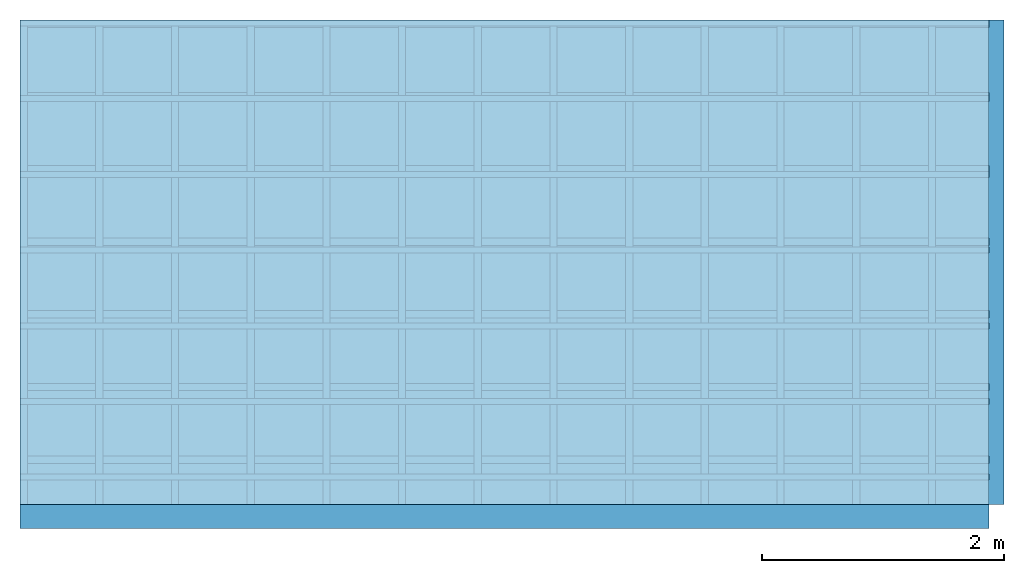
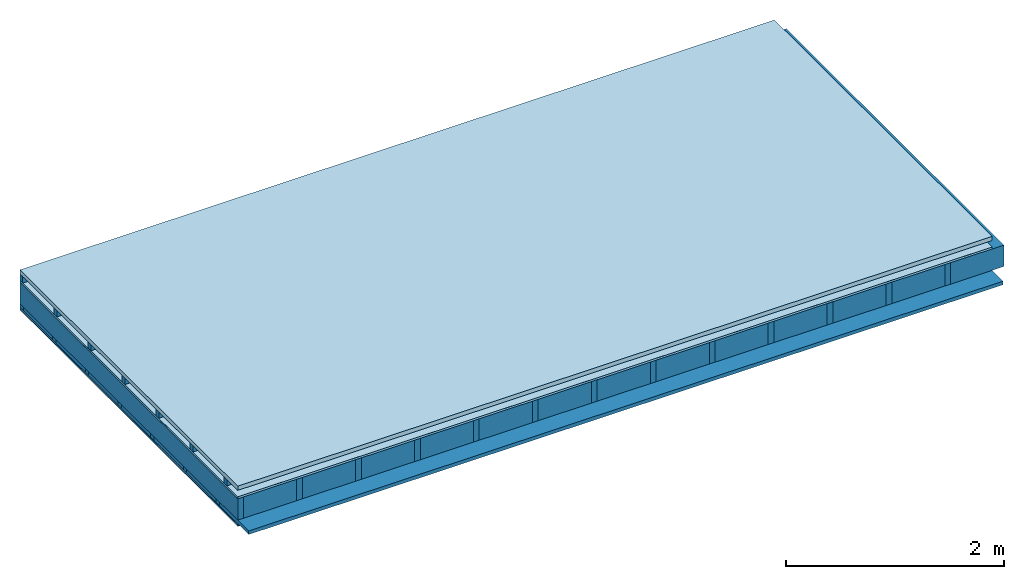
# One storey: 5 members, 5 plates, 1 element without a shape of its own.
"""IFC4 building model written with IfcOpenShell, lengths in metres."""

from ifc_helpers import new_model, si_unit, derived_unit, direction, frame, frame_2d, origin, origin_with_axes, place, context, project, spatial, rectangle, extrude, material, layer, layer_set, type_object, element, aggregate, save


model = new_model("IFC4")

# Units and contexts
plan_context = context("Plan", 3, precision=1e-05, world=origin(), true_north=direction((0.0, 1.0)))
model_context = context("Model", 3, precision=1e-05, world=origin(), true_north=direction((0.0, 1.0)))
ifc_project = project(units=[si_unit("LENGTHUNIT", "METRE"), derived_unit("SOUNDPRESSUREUNIT", [(si_unit("PRESSUREUNIT", "PASCAL", prefix="MICRO"), 0)]), si_unit("ENERGYUNIT", "JOULE", prefix="MEGA"), si_unit("MASSUNIT", "GRAM", prefix="KILO"), derived_unit("THERMALTRANSMITTANCEUNIT", [(si_unit("POWERUNIT", "WATT"), 1), (si_unit("AREAUNIT", "SQUARE_METRE"), -1), (si_unit("THERMODYNAMICTEMPERATUREUNIT", "KELVIN"), -1)]), derived_unit("AREADENSITYUNIT", [(si_unit("MASSUNIT", "GRAM", prefix="KILO"), 1), (si_unit("AREAUNIT", "SQUARE_METRE"), -1)]), derived_unit("USERDEFINED", [(si_unit("ENERGYUNIT", "JOULE", prefix="MEGA"), 1), (si_unit("AREAUNIT", "SQUARE_METRE"), -1)])], contexts=[plan_context, model_context])

# Site, building, storey
site = spatial("IfcSite", under=ifc_project)
building_placement = place(None, origin())
building = spatial("IfcBuilding", under=site, at=building_placement)
storey_placement = place(building_placement, origin())
storey = spatial("IfcBuildingStorey", under=building, at=storey_placement)

# Slab, members, plates
ifc_material_1 = material(Name="Roof tiles", Category="03.015")
ifc_layer_1 = layer(ifc_material_1, 0.047, Name="Roofing")
ifc_layer_2 = layer(None, 0.072, Name="Battens / profiles")
ifc_material_2 = material(Name="Roofing underlay", Category="09.008")
ifc_layer_3 = layer(ifc_material_2, 0.00018, Name="Under the roof")
ifc_material_3 = material(Category="10.009")
ifc_layer_4 = layer(ifc_material_3, 0.022, Name="Exterior insulation layer 1")
ifc_material_4 = material(Name="no composite action")
ifc_layer_5 = layer(ifc_material_4, 0.0, Name="Bond")
ifc_layer_6 = layer(None, 0.24, Name="Supporting structure")
ifc_material_5 = material(Name="of the art")
ifc_layer_7 = layer(ifc_material_5, 0.0, Name="Bond")
ifc_layer_8 = layer(None, 0.04, Name="Battens / profiles")
ifc_material_6 = material(Category="03.007")
ifc_layer_9 = layer(ifc_material_6, 0.015, Name="Covering below 1st layer")
ifc_layer_10 = layer(ifc_material_6, 0.015, Name="Covering below 2nd layer")
ifc_material_7 = material(Name="Glued joints")
ifc_layer_11 = layer(ifc_material_7, 0.0, Name="Surface below")
ifc_layer_set = layer_set([ifc_layer_1, ifc_layer_2, ifc_layer_3, ifc_layer_4, ifc_layer_5, ifc_layer_6, ifc_layer_7, ifc_layer_8, ifc_layer_9, ifc_layer_10, ifc_layer_11])
slab_type = type_object("IfcSlabType", Name="E0102", PredefinedType="NOTDEFINED", material=ifc_layer_set)
slab_placement = place(None, frame((0.0, 0.0, 0.0), z_axis=(0.0, 0.0, -1.0), x_axis=(1.0, 0.0, 0.0)))
slab = element("IfcSlab", 1, at=slab_placement, inside=storey, type_object=slab_type, material=ifc_layer_set, Name="Slab #1")
ifc_material_8 = material()
member_1_placement = place(slab_placement, origin())
member_1 = element("IfcMember", 2, at=member_1_placement, material=ifc_material_8, Name="Battens / profiles", context=plan_context, shape_type="SweptSolid", body=[
    extrude(rectangle(XDim=0.05, YDim=0.072, at=frame_2d((0.025, 0.036), x_axis=(1.0, 0.0))), frame((0.0, 0.0, 0.047), z_axis=(1.0, 0.0, 0.0), x_axis=(0.0, 1.0, 0.0)), (0.0, 0.0, 1.0), 8.0),
    extrude(rectangle(XDim=0.05, YDim=0.072, at=frame_2d((0.025, 0.036), x_axis=(1.0, 0.0))), frame((0.0, 0.625, 0.047), z_axis=(1.0, 0.0, 0.0), x_axis=(0.0, 1.0, 0.0)), (0.0, 0.0, 1.0), 8.0),
    extrude(rectangle(XDim=0.05, YDim=0.072, at=frame_2d((0.025, 0.036), x_axis=(1.0, 0.0))), frame((0.0, 1.25, 0.047), z_axis=(1.0, 0.0, 0.0), x_axis=(0.0, 1.0, 0.0)), (0.0, 0.0, 1.0), 8.0),
    extrude(rectangle(XDim=0.05, YDim=0.072, at=frame_2d((0.025, 0.036), x_axis=(1.0, 0.0))), frame((0.0, 1.875, 0.047), z_axis=(1.0, 0.0, 0.0), x_axis=(0.0, 1.0, 0.0)), (0.0, 0.0, 1.0), 8.0),
    extrude(rectangle(XDim=0.05, YDim=0.072, at=frame_2d((0.025, 0.036), x_axis=(1.0, 0.0))), frame((0.0, 2.5, 0.047), z_axis=(1.0, 0.0, 0.0), x_axis=(0.0, 1.0, 0.0)), (0.0, 0.0, 1.0), 8.0),
    extrude(rectangle(XDim=0.05, YDim=0.072, at=frame_2d((0.025, 0.036), x_axis=(1.0, 0.0))), frame((0.0, 3.125, 0.047), z_axis=(1.0, 0.0, 0.0), x_axis=(0.0, 1.0, 0.0)), (0.0, 0.0, 1.0), 8.0),
    extrude(rectangle(XDim=0.05, YDim=0.072, at=frame_2d((0.025, 0.036), x_axis=(1.0, 0.0))), frame((0.0, 3.75, 0.047), z_axis=(1.0, 0.0, 0.0), x_axis=(0.0, 1.0, 0.0)), (0.0, 0.0, 1.0), 8.0),
])
ifc_material_9 = material()
member_2_placement = place(slab_placement, origin())
member_2 = element("IfcMember", 3, at=member_2_placement, material=ifc_material_9, Name="Supporting structure", context=plan_context, shape_type="SweptSolid", body=[
    extrude(rectangle(XDim=0.06, YDim=0.24, at=frame_2d((0.03, 0.12), x_axis=(1.0, 0.0))), frame((0.0, 4.0, 0.14118), z_axis=(0.0, -1.0, 0.0), x_axis=(1.0, 0.0, 0.0)), (0.0, 0.0, 1.0), 4.0),
    extrude(rectangle(XDim=0.06, YDim=0.24, at=frame_2d((0.03, 0.12), x_axis=(1.0, 0.0))), frame((0.625, 4.0, 0.14118), z_axis=(0.0, -1.0, 0.0), x_axis=(1.0, 0.0, 0.0)), (0.0, 0.0, 1.0), 4.0),
    extrude(rectangle(XDim=0.06, YDim=0.24, at=frame_2d((0.03, 0.12), x_axis=(1.0, 0.0))), frame((1.25, 4.0, 0.14118), z_axis=(0.0, -1.0, 0.0), x_axis=(1.0, 0.0, 0.0)), (0.0, 0.0, 1.0), 4.0),
    extrude(rectangle(XDim=0.06, YDim=0.24, at=frame_2d((0.03, 0.12), x_axis=(1.0, 0.0))), frame((1.875, 4.0, 0.14118), z_axis=(0.0, -1.0, 0.0), x_axis=(1.0, 0.0, 0.0)), (0.0, 0.0, 1.0), 4.0),
    extrude(rectangle(XDim=0.06, YDim=0.24, at=frame_2d((0.03, 0.12), x_axis=(1.0, 0.0))), frame((2.5, 4.0, 0.14118), z_axis=(0.0, -1.0, 0.0), x_axis=(1.0, 0.0, 0.0)), (0.0, 0.0, 1.0), 4.0),
    extrude(rectangle(XDim=0.06, YDim=0.24, at=frame_2d((0.03, 0.12), x_axis=(1.0, 0.0))), frame((3.125, 4.0, 0.14118), z_axis=(0.0, -1.0, 0.0), x_axis=(1.0, 0.0, 0.0)), (0.0, 0.0, 1.0), 4.0),
    extrude(rectangle(XDim=0.06, YDim=0.24, at=frame_2d((0.03, 0.12), x_axis=(1.0, 0.0))), frame((3.75, 4.0, 0.14118), z_axis=(0.0, -1.0, 0.0), x_axis=(1.0, 0.0, 0.0)), (0.0, 0.0, 1.0), 4.0),
    extrude(rectangle(XDim=0.06, YDim=0.24, at=frame_2d((0.03, 0.12), x_axis=(1.0, 0.0))), frame((4.375, 4.0, 0.14118), z_axis=(0.0, -1.0, 0.0), x_axis=(1.0, 0.0, 0.0)), (0.0, 0.0, 1.0), 4.0),
    extrude(rectangle(XDim=0.06, YDim=0.24, at=frame_2d((0.03, 0.12), x_axis=(1.0, 0.0))), frame((5.0, 4.0, 0.14118), z_axis=(0.0, -1.0, 0.0), x_axis=(1.0, 0.0, 0.0)), (0.0, 0.0, 1.0), 4.0),
    extrude(rectangle(XDim=0.06, YDim=0.24, at=frame_2d((0.03, 0.12), x_axis=(1.0, 0.0))), frame((5.625, 4.0, 0.14118), z_axis=(0.0, -1.0, 0.0), x_axis=(1.0, 0.0, 0.0)), (0.0, 0.0, 1.0), 4.0),
    extrude(rectangle(XDim=0.06, YDim=0.24, at=frame_2d((0.03, 0.12), x_axis=(1.0, 0.0))), frame((6.25, 4.0, 0.14118), z_axis=(0.0, -1.0, 0.0), x_axis=(1.0, 0.0, 0.0)), (0.0, 0.0, 1.0), 4.0),
    extrude(rectangle(XDim=0.06, YDim=0.24, at=frame_2d((0.03, 0.12), x_axis=(1.0, 0.0))), frame((6.875, 4.0, 0.14118), z_axis=(0.0, -1.0, 0.0), x_axis=(1.0, 0.0, 0.0)), (0.0, 0.0, 1.0), 4.0),
    extrude(rectangle(XDim=0.06, YDim=0.24, at=frame_2d((0.03, 0.12), x_axis=(1.0, 0.0))), frame((7.5, 4.0, 0.14118), z_axis=(0.0, -1.0, 0.0), x_axis=(1.0, 0.0, 0.0)), (0.0, 0.0, 1.0), 4.0),
])
ifc_material_10 = material()
member_3_placement = place(slab_placement, origin())
member_3 = element("IfcMember", 4, at=member_3_placement, material=ifc_material_10, Name="Cavity", context=plan_context, shape_type="SweptSolid", body=[
    extrude(rectangle(XDim=0.565, YDim=0.24, at=frame_2d((0.2825, 0.12), x_axis=(1.0, 0.0))), frame((0.06, 4.0, 0.14118), z_axis=(0.0, -1.0, 0.0), x_axis=(1.0, 0.0, 0.0)), (0.0, 0.0, 1.0), 4.0),
    extrude(rectangle(XDim=0.565, YDim=0.24, at=frame_2d((0.2825, 0.12), x_axis=(1.0, 0.0))), frame((0.685, 4.0, 0.14118), z_axis=(0.0, -1.0, 0.0), x_axis=(1.0, 0.0, 0.0)), (0.0, 0.0, 1.0), 4.0),
    extrude(rectangle(XDim=0.565, YDim=0.24, at=frame_2d((0.2825, 0.12), x_axis=(1.0, 0.0))), frame((1.31, 4.0, 0.14118), z_axis=(0.0, -1.0, 0.0), x_axis=(1.0, 0.0, 0.0)), (0.0, 0.0, 1.0), 4.0),
    extrude(rectangle(XDim=0.565, YDim=0.24, at=frame_2d((0.2825, 0.12), x_axis=(1.0, 0.0))), frame((1.935, 4.0, 0.14118), z_axis=(0.0, -1.0, 0.0), x_axis=(1.0, 0.0, 0.0)), (0.0, 0.0, 1.0), 4.0),
    extrude(rectangle(XDim=0.565, YDim=0.24, at=frame_2d((0.2825, 0.12), x_axis=(1.0, 0.0))), frame((2.56, 4.0, 0.14118), z_axis=(0.0, -1.0, 0.0), x_axis=(1.0, 0.0, 0.0)), (0.0, 0.0, 1.0), 4.0),
    extrude(rectangle(XDim=0.565, YDim=0.24, at=frame_2d((0.2825, 0.12), x_axis=(1.0, 0.0))), frame((3.185, 4.0, 0.14118), z_axis=(0.0, -1.0, 0.0), x_axis=(1.0, 0.0, 0.0)), (0.0, 0.0, 1.0), 4.0),
    extrude(rectangle(XDim=0.565, YDim=0.24, at=frame_2d((0.2825, 0.12), x_axis=(1.0, 0.0))), frame((3.81, 4.0, 0.14118), z_axis=(0.0, -1.0, 0.0), x_axis=(1.0, 0.0, 0.0)), (0.0, 0.0, 1.0), 4.0),
    extrude(rectangle(XDim=0.565, YDim=0.24, at=frame_2d((0.2825, 0.12), x_axis=(1.0, 0.0))), frame((4.435, 4.0, 0.14118), z_axis=(0.0, -1.0, 0.0), x_axis=(1.0, 0.0, 0.0)), (0.0, 0.0, 1.0), 4.0),
    extrude(rectangle(XDim=0.565, YDim=0.24, at=frame_2d((0.2825, 0.12), x_axis=(1.0, 0.0))), frame((5.06, 4.0, 0.14118), z_axis=(0.0, -1.0, 0.0), x_axis=(1.0, 0.0, 0.0)), (0.0, 0.0, 1.0), 4.0),
    extrude(rectangle(XDim=0.565, YDim=0.24, at=frame_2d((0.2825, 0.12), x_axis=(1.0, 0.0))), frame((5.685, 4.0, 0.14118), z_axis=(0.0, -1.0, 0.0), x_axis=(1.0, 0.0, 0.0)), (0.0, 0.0, 1.0), 4.0),
    extrude(rectangle(XDim=0.565, YDim=0.24, at=frame_2d((0.2825, 0.12), x_axis=(1.0, 0.0))), frame((6.31, 4.0, 0.14118), z_axis=(0.0, -1.0, 0.0), x_axis=(1.0, 0.0, 0.0)), (0.0, 0.0, 1.0), 4.0),
    extrude(rectangle(XDim=0.565, YDim=0.24, at=frame_2d((0.2825, 0.12), x_axis=(1.0, 0.0))), frame((6.935, 4.0, 0.14118), z_axis=(0.0, -1.0, 0.0), x_axis=(1.0, 0.0, 0.0)), (0.0, 0.0, 1.0), 4.0),
    extrude(rectangle(XDim=0.565, YDim=0.24, at=frame_2d((0.2825, 0.12), x_axis=(1.0, 0.0))), frame((7.56, 4.0, 0.14118), z_axis=(0.0, -1.0, 0.0), x_axis=(1.0, 0.0, 0.0)), (0.0, 0.0, 1.0), 4.0),
])
ifc_material_11 = material()
member_4_placement = place(slab_placement, origin())
member_4 = element("IfcMember", 5, at=member_4_placement, material=ifc_material_11, Name="Battens / profiles", context=plan_context, shape_type="SweptSolid", body=[
    extrude(rectangle(XDim=0.06, YDim=0.04, at=frame_2d((0.03, 0.02), x_axis=(1.0, 0.0))), frame((0.0, 0.0, 0.38118), z_axis=(1.0, 0.0, 0.0), x_axis=(0.0, 1.0, 0.0)), (0.0, 0.0, 1.0), 8.0),
    extrude(rectangle(XDim=0.06, YDim=0.04, at=frame_2d((0.03, 0.02), x_axis=(1.0, 0.0))), frame((0.0, 0.6, 0.38118), z_axis=(1.0, 0.0, 0.0), x_axis=(0.0, 1.0, 0.0)), (0.0, 0.0, 1.0), 8.0),
    extrude(rectangle(XDim=0.06, YDim=0.04, at=frame_2d((0.03, 0.02), x_axis=(1.0, 0.0))), frame((0.0, 1.2, 0.38118), z_axis=(1.0, 0.0, 0.0), x_axis=(0.0, 1.0, 0.0)), (0.0, 0.0, 1.0), 8.0),
    extrude(rectangle(XDim=0.06, YDim=0.04, at=frame_2d((0.03, 0.02), x_axis=(1.0, 0.0))), frame((0.0, 1.8, 0.38118), z_axis=(1.0, 0.0, 0.0), x_axis=(0.0, 1.0, 0.0)), (0.0, 0.0, 1.0), 8.0),
    extrude(rectangle(XDim=0.06, YDim=0.04, at=frame_2d((0.03, 0.02), x_axis=(1.0, 0.0))), frame((0.0, 2.4, 0.38118), z_axis=(1.0, 0.0, 0.0), x_axis=(0.0, 1.0, 0.0)), (0.0, 0.0, 1.0), 8.0),
    extrude(rectangle(XDim=0.06, YDim=0.04, at=frame_2d((0.03, 0.02), x_axis=(1.0, 0.0))), frame((0.0, 3.0, 0.38118), z_axis=(1.0, 0.0, 0.0), x_axis=(0.0, 1.0, 0.0)), (0.0, 0.0, 1.0), 8.0),
    extrude(rectangle(XDim=0.06, YDim=0.04, at=frame_2d((0.03, 0.02), x_axis=(1.0, 0.0))), frame((0.0, 3.6, 0.38118), z_axis=(1.0, 0.0, 0.0), x_axis=(0.0, 1.0, 0.0)), (0.0, 0.0, 1.0), 8.0),
])
ifc_material_12 = material(Name="Mineral wool")
member_5_placement = place(slab_placement, origin())
member_5 = element("IfcMember", 6, at=member_5_placement, material=ifc_material_12, Name="Cavity", context=plan_context, shape_type="SweptSolid", body=[
    extrude(rectangle(XDim=0.54, YDim=0.04, at=frame_2d((0.27, 0.02), x_axis=(1.0, 0.0))), frame((0.0, 0.06, 0.38118), z_axis=(1.0, 0.0, 0.0), x_axis=(0.0, 1.0, 0.0)), (0.0, 0.0, 1.0), 8.0),
    extrude(rectangle(XDim=0.54, YDim=0.04, at=frame_2d((0.27, 0.02), x_axis=(1.0, 0.0))), frame((0.0, 0.66, 0.38118), z_axis=(1.0, 0.0, 0.0), x_axis=(0.0, 1.0, 0.0)), (0.0, 0.0, 1.0), 8.0),
    extrude(rectangle(XDim=0.54, YDim=0.04, at=frame_2d((0.27, 0.02), x_axis=(1.0, 0.0))), frame((0.0, 1.26, 0.38118), z_axis=(1.0, 0.0, 0.0), x_axis=(0.0, 1.0, 0.0)), (0.0, 0.0, 1.0), 8.0),
    extrude(rectangle(XDim=0.54, YDim=0.04, at=frame_2d((0.27, 0.02), x_axis=(1.0, 0.0))), frame((0.0, 1.86, 0.38118), z_axis=(1.0, 0.0, 0.0), x_axis=(0.0, 1.0, 0.0)), (0.0, 0.0, 1.0), 8.0),
    extrude(rectangle(XDim=0.54, YDim=0.04, at=frame_2d((0.27, 0.02), x_axis=(1.0, 0.0))), frame((0.0, 2.46, 0.38118), z_axis=(1.0, 0.0, 0.0), x_axis=(0.0, 1.0, 0.0)), (0.0, 0.0, 1.0), 8.0),
    extrude(rectangle(XDim=0.54, YDim=0.04, at=frame_2d((0.27, 0.02), x_axis=(1.0, 0.0))), frame((0.0, 3.06, 0.38118), z_axis=(1.0, 0.0, 0.0), x_axis=(0.0, 1.0, 0.0)), (0.0, 0.0, 1.0), 8.0),
    extrude(rectangle(XDim=0.54, YDim=0.04, at=frame_2d((0.27, 0.02), x_axis=(1.0, 0.0))), frame((0.0, 3.66, 0.38118), z_axis=(1.0, 0.0, 0.0), x_axis=(0.0, 1.0, 0.0)), (0.0, 0.0, 1.0), 8.0),
])
plate_1_placement = place(slab_placement, origin())
plate_1 = element("IfcPlate", 7, at=plate_1_placement, material=ifc_material_1, Name="Roofing", context=plan_context, shape_type="SweptSolid", body=[
    extrude(rectangle(XDim=8.0, YDim=4.0, at=frame_2d((4.0, 2.0), x_axis=(1.0, 0.0))), origin_with_axes(), (0.0, 0.0, 1.0), 0.047),
])
plate_2_placement = place(slab_placement, origin())
plate_2 = element("IfcPlate", 8, at=plate_2_placement, material=ifc_material_2, Name="Under the roof", context=plan_context, shape_type="SweptSolid", body=[
    extrude(rectangle(XDim=8.0, YDim=4.0, at=frame_2d((4.0, 2.0), x_axis=(1.0, 0.0))), frame((0.0, 0.0, 0.119), z_axis=(0.0, 0.0, 1.0), x_axis=(1.0, 0.0, 0.0)), (0.0, 0.0, 1.0), 0.00018),
])
plate_3_placement = place(slab_placement, origin())
plate_3 = element("IfcPlate", 9, at=plate_3_placement, material=ifc_material_3, Name="Exterior insulation layer 1", context=plan_context, shape_type="SweptSolid", body=[
    extrude(rectangle(XDim=8.0, YDim=4.0, at=frame_2d((4.0, 2.0), x_axis=(1.0, 0.0))), frame((0.0, 0.0, 0.11918), z_axis=(0.0, 0.0, 1.0), x_axis=(1.0, 0.0, 0.0)), (0.0, 0.0, 1.0), 0.022),
])
plate_4_placement = place(slab_placement, origin())
plate_4 = element("IfcPlate", 10, at=plate_4_placement, material=ifc_material_6, Name="Covering below 1st layer", context=plan_context, shape_type="SweptSolid", body=[
    extrude(rectangle(XDim=8.0, YDim=4.0, at=frame_2d((4.0, 2.0), x_axis=(1.0, 0.0))), frame((0.0, 0.0, 0.42118), z_axis=(0.0, 0.0, 1.0), x_axis=(1.0, 0.0, 0.0)), (0.0, 0.0, 1.0), 0.015),
])
plate_5_placement = place(slab_placement, origin())
plate_5 = element("IfcPlate", 11, at=plate_5_placement, material=ifc_material_6, Name="Covering below 2nd layer", context=plan_context, shape_type="SweptSolid", body=[
    extrude(rectangle(XDim=8.0, YDim=4.0, at=frame_2d((4.0, 2.0), x_axis=(1.0, 0.0))), frame((0.0, 0.0, 0.43618), z_axis=(0.0, 0.0, 1.0), x_axis=(1.0, 0.0, 0.0)), (0.0, 0.0, 1.0), 0.015),
])
aggregate(slab, [plate_1, member_1, plate_2, plate_3, member_2, member_3, member_4, member_5, plate_4, plate_5])

save(model, "model.ifc")
